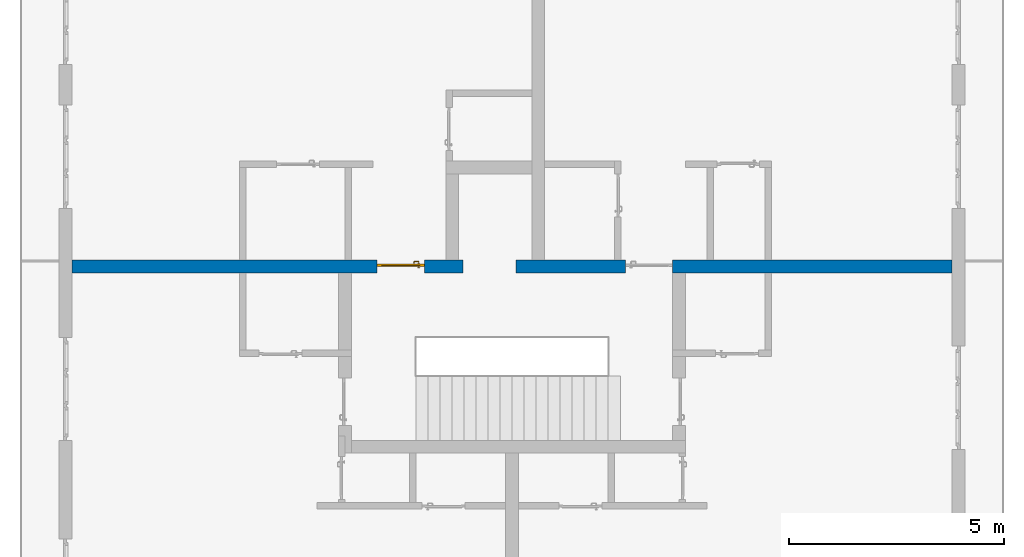
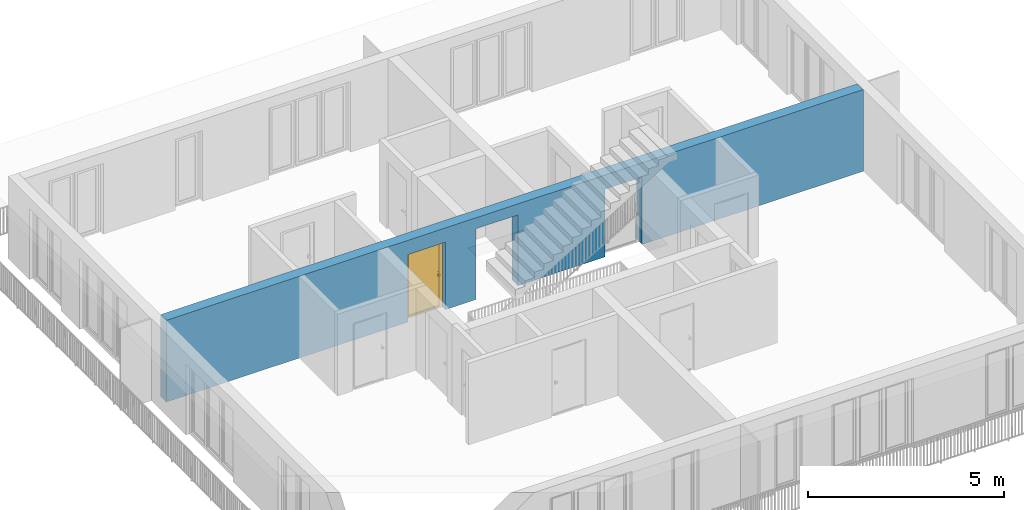
# One storey, part 13 of 48: 1 door, 1 wall, 3 openings.
"""IFC4 building model written with IfcOpenShell, lengths in metres."""

import ifcopenshell
import ifcopenshell.guid

model = None  # the IFC model being written
_history = None  # IfcOwnerHistory: only IFC2X3 demands one
_inside = {}  # id of a spatial element -> (the spatial element, [elements in it])
_under = {}  # id of a project, library or spatial element -> (it, [spatial elements below it])
_declared = {}  # id of a project -> (the project, [libraries it declares])
_typed = {}  # id of a type object -> (the type object, [elements of that type])
_made_of = {}  # id of a material, layer set ... -> (it, [elements and type objects made of it])


def new_model(schema):
    """Start an empty IFC model of exactly this schema.

    Asked for "IFC4X3", IfcOpenShell would pick the latest addendum, in which some entities
    have other attributes; the version numbers below select the first issue.
    IFC2X3 requires an IfcOwnerHistory on every rooted entity: one is made here for all.
    """
    global model, _history
    if schema == "IFC4X3":
        model = ifcopenshell.file(schema_version=(4, 3, 0, 0))
    else:
        model = ifcopenshell.file(schema=schema)
    _inside.clear()
    _under.clear()
    _declared.clear()
    _typed.clear()
    _made_of.clear()
    _history = None
    if model.schema == "IFC2X3":
        org = make("IfcOrganization", Name="unknown")
        user = make(
            "IfcPersonAndOrganization",
            ThePerson=make("IfcPerson", FamilyName="unknown"),
            TheOrganization=org,
        )
        app = make(
            "IfcApplication",
            ApplicationDeveloper=org,
            Version="unknown",
            ApplicationFullName="unknown",
            ApplicationIdentifier="unknown",
        )
        _history = make(
            "IfcOwnerHistory",
            OwningUser=user,
            OwningApplication=app,
            ChangeAction="ADDED",
            CreationDate=0,
        )
    return model


def make(cls, **values):
    """One entity of the class cls with the attributes given. An attribute that is None is left unset."""
    return model.create_entity(
        cls, **{name: value for name, value in values.items() if value is not None}
    )


def entity(cls, *values):
    """Any entity or typed value of the class cls, its attributes in the order of the schema. None: left unset."""
    e = model.create_entity(cls)
    for i, value in enumerate(values):
        if value is not None:
            e[i] = value
    return e


def rooted(cls, **values):
    """An entity with a GlobalId (a new one), such as an element, a storey or a relation."""
    return make(cls, GlobalId=ifcopenshell.guid.new(), OwnerHistory=_history, **values)


def si_unit(unit_type, name, prefix=None):
    """IfcSIUnit, for example si_unit("LENGTHUNIT", "METRE", prefix="MILLI")."""
    return make("IfcSIUnit", UnitType=unit_type, Prefix=prefix, Name=name)


def converted_unit(unit_type, name, factor, base, dimensions=None, offset=None):
    """IfcConversionBasedUnit, such as the inch: factor (a typed value) times the base unit."""
    return make(
        "IfcConversionBasedUnit"
        if offset is None
        else "IfcConversionBasedUnitWithOffset",
        ConversionOffset=offset,
        Dimensions=None
        if dimensions is None
        else entity("IfcDimensionalExponents", *dimensions),
        UnitType=unit_type,
        Name=name,
        ConversionFactor=make(
            "IfcMeasureWithUnit", ValueComponent=factor, UnitComponent=base
        ),
    )


def derived_unit(unit_type, elements):
    """IfcDerivedUnit: a product of units, each with its exponent."""
    return make(
        "IfcDerivedUnit",
        Elements=[
            make("IfcDerivedUnitElement", Unit=unit, Exponent=power)
            for unit, power in elements
        ],
        UnitType=unit_type,
    )


def assignment(units):
    """IfcUnitAssignment: the units of a project."""
    return None if units is None else make("IfcUnitAssignment", Units=units)


def point(xyz):
    """IfcCartesianPoint."""
    return None if xyz is None else make("IfcCartesianPoint", Coordinates=xyz)


def direction(xyz):
    """IfcDirection."""
    return None if xyz is None else make("IfcDirection", DirectionRatios=xyz)


def frame(location, z_axis=None, x_axis=None):
    """IfcAxis2Placement3D, a coordinate frame: its origin and axes. An axis left out is left unset."""
    return make(
        "IfcAxis2Placement3D",
        Location=point(location),
        Axis=direction(z_axis),
        RefDirection=direction(x_axis),
    )


def origin_with_axes():
    """The frame at (0, 0, 0) with the z axis (0, 0, 1) and the x axis (1, 0, 0) written out."""
    return frame((0.0, 0.0, 0.0), z_axis=(0.0, 0.0, 1.0), x_axis=(1.0, 0.0, 0.0))


def place(relative_to, where):
    """IfcLocalPlacement: puts the frame where relative to a parent placement (None: the world)."""
    return make(
        "IfcLocalPlacement", PlacementRelTo=relative_to, RelativePlacement=where
    )


def context(
    kind, dimensions, precision=None, world=None, true_north=None, identifier=None
):
    """IfcGeometricRepresentationContext, for example the 3D "Model" context."""
    return make(
        "IfcGeometricRepresentationContext",
        ContextIdentifier=identifier,
        ContextType=kind,
        CoordinateSpaceDimension=dimensions,
        Precision=precision,
        WorldCoordinateSystem=world,
        TrueNorth=true_north,
    )


def subcontext(parent, identifier, kind, view, scale=None):
    """IfcGeometricRepresentationSubContext, for example "Body" below "Model"."""
    return make(
        "IfcGeometricRepresentationSubContext",
        ContextIdentifier=identifier,
        ContextType=kind,
        ParentContext=parent,
        TargetScale=scale,
        TargetView=view,
    )


def project(units=None, contexts=None):
    """IfcProject with its units and contexts."""
    return rooted(
        "IfcProject",
        Name="project",
        RepresentationContexts=contexts,
        UnitsInContext=assignment(units),
    )


def spatial(cls, under=None, at=None, **own):
    """A site, building, storey or space (cls), placed at a placement, below another one or the project."""
    s = rooted(cls, ObjectPlacement=at, **own)
    if under is not None:
        _under.setdefault(under.id(), (under, []))[1].append(s)
    return s


def point_list(points):
    """IfcCartesianPointList2D or 3D."""
    cls = (
        "IfcCartesianPointList2D" if len(points[0]) == 2 else "IfcCartesianPointList3D"
    )
    return make(cls, CoordList=points)


def polygons(points, faces, closed=None, point_numbers=None):
    """IfcPolygonalFaceSet: a face is its outer loop, then its inner loops; points numbered from 1."""
    made = []
    for loops in faces:
        if len(loops) == 1:
            made.append(make("IfcIndexedPolygonalFace", CoordIndex=loops[0]))
        else:
            made.append(
                make(
                    "IfcIndexedPolygonalFaceWithVoids",
                    CoordIndex=loops[0],
                    InnerCoordIndices=loops[1:],
                )
            )
    return make(
        "IfcPolygonalFaceSet",
        Coordinates=point_list(points),
        Closed=closed,
        Faces=made,
        PnIndex=point_numbers,
    )


def shape(context_of_items, identifier, shape_type, items):
    """IfcShapeRepresentation: the items that make up one representation, for example the "Body"."""
    return make(
        "IfcShapeRepresentation",
        ContextOfItems=context_of_items,
        RepresentationIdentifier=identifier,
        RepresentationType=shape_type,
        Items=items,
    )


def source(mapping_origin, context_of_items, identifier, shape_type, items):
    """IfcRepresentationMap: a shape defined once, which mapped items show again and again."""
    return make(
        "IfcRepresentationMap",
        MappingOrigin=mapping_origin,
        MappedRepresentation=shape(context_of_items, identifier, shape_type, items),
    )


def transform(
    local_origin,
    x_axis=None,
    y_axis=None,
    z_axis=None,
    scale=None,
    scale2=None,
    scale3=None,
    uniform=True,
):
    """IfcCartesianTransformationOperator3D, or its non-uniform kind. x_axis, y_axis, z_axis: its Axis1, 2, 3."""
    if uniform:
        return make(
            "IfcCartesianTransformationOperator3D",
            Axis1=direction(x_axis),
            Axis2=direction(y_axis),
            LocalOrigin=point(local_origin),
            Scale=scale,
            Axis3=direction(z_axis),
        )
    return make(
        "IfcCartesianTransformationOperator3DnonUniform",
        Axis1=direction(x_axis),
        Axis2=direction(y_axis),
        LocalOrigin=point(local_origin),
        Scale=scale,
        Axis3=direction(z_axis),
        Scale2=scale2,
        Scale3=scale3,
    )


def mapped(mapping_source, mapping_target):
    """IfcMappedItem: shows the shape of a source again, moved by a transform."""
    return make(
        "IfcMappedItem", MappingSource=mapping_source, MappingTarget=mapping_target
    )


def material(Name=None, Category=None):
    """IfcMaterial."""
    return make("IfcMaterial", Name=Name, Category=Category)


def made_of(thing, what):
    """Note that an element or type object is made of a material, layer set ...; save() writes the relation."""
    if what is not None:
        _made_of.setdefault(what.id(), (what, []))[1].append(thing)
    return thing


def type_object(cls, material=None, **own):
    """A type object (cls), such as IfcWallType, which elements share."""
    return made_of(rooted(cls, **own), material)


def element(
    cls,
    number,
    at=None,
    inside=None,
    cuts=None,
    type_object=None,
    material=None,
    context=None,
    identifier="Body",
    shape_type=None,
    held_by="IfcProductDefinitionShape",
    body=None,
    shapes=None,
    **own,
):
    """One element of the class cls, such as IfcWall. Its Tag is "e" and its number.

    at: its placement. inside: the storey or other place that contains it. cuts: it is an
    opening in that element (IfcRelVoidsElement). A single representation is given by context,
    identifier, shape_type and body (its items); several are given by shapes. held_by: the class
    of the entity that holds the representations. save() writes the other relations.
    """
    e = rooted(cls, Tag="e%d" % number, ObjectPlacement=at, **own)
    if body is not None:
        shapes = [shape(context, identifier, shape_type, body)]
    if shapes is not None:
        e.Representation = make(held_by, Representations=shapes)
    if inside is not None:
        _inside.setdefault(inside.id(), (inside, []))[1].append(e)
    if cuts is not None:
        rooted(
            "IfcRelVoidsElement", RelatingBuildingElement=cuts, RelatedOpeningElement=e
        )
    if type_object is not None:
        _typed.setdefault(type_object.id(), (type_object, []))[1].append(e)
    return made_of(e, material)


def fill(opening, filler):
    """IfcRelFillsElement: the door or window that sits in an opening."""
    return rooted(
        "IfcRelFillsElement",
        RelatingOpeningElement=opening,
        RelatedBuildingElement=filler,
    )


def aggregate(whole, parts):
    """IfcRelAggregates: a whole, such as a stair, and the parts it consists of."""
    return rooted("IfcRelAggregates", RelatingObject=whole, RelatedObjects=parts)


def save(model, path):
    """Write the relations noted so far, then the file.

    IfcRelAggregates (storeys below a building ...), IfcRelContainedInSpatialStructure (elements
    in a storey), IfcRelDefinesByType, IfcRelAssociatesMaterial and IfcRelDeclares: one each for
    every whole, place, type object, material and project.
    """
    for whole, parts in _under.values():
        aggregate(whole, parts)
    for where, things in _inside.values():
        rooted(
            "IfcRelContainedInSpatialStructure",
            RelatedElements=things,
            RelatingStructure=where,
        )
    for kind, things in _typed.values():
        rooted("IfcRelDefinesByType", RelatedObjects=things, RelatingType=kind)
    for what, things in _made_of.values():
        rooted("IfcRelAssociatesMaterial", RelatedObjects=things, RelatingMaterial=what)
    for by, libraries in _declared.values():
        rooted("IfcRelDeclares", RelatingContext=by, RelatedDefinitions=libraries)
    model.write(path)


model = new_model("IFC4")

# Units and contexts
model_context = context("Model", 3, precision=1e-05, world=origin_with_axes(), true_north=direction((0.0, 1.0)))
body_context = subcontext(model_context, "Body", "Model", "MODEL_VIEW")
ifc_project = project(units=[si_unit("LENGTHUNIT", "METRE"), si_unit("AREAUNIT", "SQUARE_METRE"), si_unit("VOLUMEUNIT", "CUBIC_METRE"), converted_unit("PLANEANGLEUNIT", "DEGREE", entity("IfcPlaneAngleMeasure", 0.0174532925199), si_unit("PLANEANGLEUNIT", "RADIAN"), dimensions=[0, 0, 0, 0, 0, 0, 0]), converted_unit("TIMEUNIT", "Year", entity("IfcTimeMeasure", 31556926.0), si_unit("TIMEUNIT", "SECOND"), dimensions=[0, 0, 1, 0, 0, 0, 0]), si_unit("MASSUNIT", "GRAM", prefix="KILO"), si_unit("THERMODYNAMICTEMPERATUREUNIT", "DEGREE_CELSIUS"), si_unit("LUMINOUSINTENSITYUNIT", "LUMEN"), si_unit("ENERGYUNIT", "JOULE", prefix="MEGA"), derived_unit("THERMALCONDUCTANCEUNIT", [(si_unit("POWERUNIT", "WATT"), 1), (si_unit("LENGTHUNIT", "METRE"), -1), (si_unit("THERMODYNAMICTEMPERATUREUNIT", "KELVIN"), -1)]), derived_unit("SPECIFICHEATCAPACITYUNIT", [(si_unit("ENERGYUNIT", "JOULE"), 1), (si_unit("MASSUNIT", "GRAM", prefix="KILO"), -1), (si_unit("THERMODYNAMICTEMPERATUREUNIT", "KELVIN"), -1)]), derived_unit("MASSDENSITYUNIT", [(si_unit("MASSUNIT", "GRAM", prefix="KILO"), 1), (si_unit("VOLUMEUNIT", "CUBIC_METRE"), -1)])], contexts=[model_context])

# Site, building, storey
site_placement = place(None, origin_with_axes())
site = spatial("IfcSite", under=ifc_project, at=site_placement, CompositionType="ELEMENT")
building_placement = place(site_placement, origin_with_axes())
building = spatial("IfcBuilding", under=site, at=building_placement, CompositionType="ELEMENT")
storey_placement = place(building_placement, frame((0.0, 0.0, 3.4), z_axis=(0.0, 0.0, 1.0), x_axis=(1.0, 0.0, 0.0)))
storey = spatial("IfcBuildingStorey", under=building, at=storey_placement, Name="1. Geschoss", CompositionType="ELEMENT", Elevation=3.4)

# Wall, openings, door
ifc_material = material()
wall_type = type_object("IfcWallType", Name="300", PredefinedType="NOTDEFINED")
wall_placement = place(storey_placement, frame((-11.7421993804, 1.37118776896, 0.0), z_axis=(0.0, 0.0, 1.0), x_axis=(1.0, 0.0, 0.0)))
wall = element("IfcWall", 1, at=wall_placement, inside=storey, type_object=wall_type, material=ifc_material, Name="Wand-001", PredefinedType="NOTDEFINED", context=body_context, shape_type="Tessellation", body=[
    polygons([(9.4, 0.3, 2.2), (9.4, 0.3, 0.0), (8.5, 0.3, 0.0), (8.5, 0.3, 2.1), (7.4, 0.3, 2.1), (7.4, 0.3, 0.0), (0.3, 0.3, 0.0), (0.3, 0.3, 2.54), (20.78, 0.3, 2.54), (20.78, 0.3, 0.0), (14.28, 0.3, 0.0), (14.28, 0.3, 2.1), (13.18, 0.3, 2.1), (13.18, 0.3, 0.0), (10.63, 0.3, 0.0), (10.63, 0.3, 2.2), (9.4, 0.0, 2.2), (9.4, 0.0, 0.0), (8.5, 0.0, 0.0), (8.5, 0.0, 2.1), (7.4, 0.0, 2.1), (7.4, 0.0, 0.0), (0.3, 0.0, 0.0), (0.3, 0.0, 2.54), (20.78, 0.0, 2.54), (20.78, 0.0, 0.0), (14.28, 0.0, 0.0), (14.28, 0.0, 2.1), (13.18, 0.0, 2.1), (13.18, 0.0, 0.0), (10.63, 0.0, 0.0), (10.63, 0.0, 2.2)], [[[1, 2, 3, 4, 5, 6, 7, 8, 9, 10, 11, 12, 13, 14, 15, 16]], [[2, 1, 17, 18]], [[2, 18, 19, 3]], [[20, 4, 3, 19]], [[21, 5, 4, 20]], [[22, 6, 5, 21]], [[7, 6, 22, 23]], [[24, 8, 7, 23]], [[25, 9, 8, 24]], [[9, 25, 26, 10]], [[10, 26, 27, 11]], [[11, 27, 28, 12]], [[12, 28, 29, 13]], [[13, 29, 30, 14]], [[31, 15, 14, 30]], [[16, 15, 31, 32]], [[1, 16, 32, 17]], [[32, 31, 30, 29, 28, 27, 26, 25, 24, 23, 22, 21, 20, 19, 18, 17]]], closed=True),
])
opening_1_placement = place(wall_placement, frame((7.95, 0.0, 0.0), z_axis=(0.0, 0.0, 1.0), x_axis=(1.0, 0.0, 0.0)))
opening_1 = element("IfcOpeningElement", 2, at=opening_1_placement, cuts=wall, context=body_context, identifier="Reference", shape_type="Tessellation", body=[
    polygons([(0.55, 0.15, 0.0), (0.55, 0.15, 2.1), (0.55, -0.001, 2.1), (0.55, -0.001, 0.0), (0.55, 0.301, 0.0), (0.55, 0.301, 2.1), (-0.55, 0.15, 2.1), (-0.55, -0.001, 2.1), (-0.55, 0.301, 2.1), (-0.55, -0.001, 0.0), (-0.55, 0.15, 0.0), (-0.55, 0.301, 0.0)], [[[1, 2, 3, 4]], [[2, 1, 5, 6]], [[7, 8, 3, 2, 6, 9]], [[8, 10, 4, 3]], [[1, 4, 10, 11, 12, 5]], [[6, 5, 12, 9]], [[7, 11, 10, 8]], [[11, 7, 9, 12]]], closed=True),
])
opening_2_placement = place(wall_placement, frame((13.73, 0.0, 0.0), z_axis=(0.0, 0.0, 1.0), x_axis=(1.0, 0.0, 0.0)))
element("IfcOpeningElement", 3, at=opening_2_placement, cuts=wall, context=body_context, identifier="Reference", shape_type="Tessellation", body=[
    polygons([(0.55, 0.15, 0.0), (0.55, 0.15, 2.1), (0.55, -0.001, 2.1), (0.55, -0.001, 0.0), (0.55, 0.301, 0.0), (0.55, 0.301, 2.1), (-0.55, 0.15, 2.1), (-0.55, -0.001, 2.1), (-0.55, 0.301, 2.1), (-0.55, -0.001, 0.0), (-0.55, 0.15, 0.0), (-0.55, 0.301, 0.0)], [[[1, 2, 3, 4]], [[2, 1, 5, 6]], [[7, 8, 3, 2, 6, 9]], [[8, 10, 4, 3]], [[1, 4, 10, 11, 12, 5]], [[6, 5, 12, 9]], [[7, 11, 10, 8]], [[11, 7, 9, 12]]], closed=True),
])
opening_3_placement = place(wall_placement, frame((10.015, 0.0, 0.0), z_axis=(0.0, 0.0, 1.0), x_axis=(1.0, 0.0, 0.0)))
element("IfcOpeningElement", 4, at=opening_3_placement, cuts=wall, context=body_context, identifier="Reference", shape_type="Tessellation", body=[
    polygons([(-0.615, -0.001, 2.2), (-0.615, -0.001, 0.0), (0.615, -0.001, 0.0), (0.615, -0.001, 2.2), (-0.615, 0.301, 2.2), (-0.615, 0.301, 0.0), (0.615, 0.301, 0.0), (0.615, 0.301, 2.2)], [[[1, 2, 3, 4]], [[5, 6, 2, 1]], [[6, 7, 3, 2]], [[7, 8, 4, 3]], [[8, 5, 1, 4]], [[7, 6, 5, 8]]], closed=True),
])
door_type = type_object("IfcDoorType", Name="Eingang 01 1-Fl 26", OperationType="SINGLE_SWING_LEFT", PredefinedType="DOOR")
shared_shape = source(origin_with_axes(), body_context, "Body", "Tessellation", [
    polygons([(-0.55, -0.05, 0.0), (-0.55, -0.05, 2.1), (-0.55, -0.03, 2.1), (-0.55, -0.03, 0.0), (-0.45, -0.05, 0.0), (-0.45, -0.05, 2.0), (-0.1301, -0.05, 2.0), (-0.0001, -0.05, 2.0), (0.45, -0.05, 2.0), (0.45, -0.05, 0.0), (0.55, -0.05, 0.0), (0.55, -0.05, 2.1), (0.55, -0.03, 2.1), (0.55, -0.03, 0.0), (0.45, -0.03, 0.0), (0.45, -0.03, 2.0), (-0.0001, -0.03, 2.0), (-0.1301, -0.03, 2.0), (-0.45, -0.03, 2.0), (-0.45, -0.03, 0.0)], [[[1, 2, 3, 4]], [[1, 5, 6, 7, 8, 9, 10, 11, 12, 2]], [[2, 12, 13, 3]], [[4, 3, 13, 14, 15, 16, 17, 18, 19, 20]], [[5, 1, 4, 20]], [[6, 5, 20, 19]], [[7, 6, 19, 18]], [[8, 7, 18, 17]], [[9, 8, 17, 16]], [[10, 9, 16, 15]], [[11, 10, 15, 14]], [[12, 11, 14, 13]]], closed=True),
    polygons([(-0.55, -0.03, 0.0), (-0.55, -0.03, 2.1), (-0.55, 0.0, 2.1), (-0.55, 0.0, 0.0), (-0.48, -0.03, 0.0), (-0.48, -0.03, 2.03), (-0.1001, -0.03, 2.03), (-0.0301, -0.03, 2.03), (0.48, -0.03, 2.03), (0.48, -0.03, 0.0), (0.55, -0.03, 0.0), (0.55, -0.03, 2.1), (0.55, 0.0, 2.1), (0.55, 0.0, 0.0), (0.48, 0.0, 0.0), (0.48, 0.0, 2.03), (-0.0301, 0.0, 2.03), (-0.1001, 0.0, 2.03), (-0.48, 0.0, 2.03), (-0.48, 0.0, 0.0)], [[[1, 2, 3, 4]], [[1, 5, 6, 7, 8, 9, 10, 11, 12, 2]], [[2, 12, 13, 3]], [[4, 3, 13, 14, 15, 16, 17, 18, 19, 20]], [[5, 1, 4, 20]], [[6, 5, 20, 19]], [[7, 6, 19, 18]], [[8, 7, 18, 17]], [[9, 8, 17, 16]], [[10, 9, 16, 15]], [[11, 10, 15, 14]], [[12, 11, 14, 13]]], closed=True),
    polygons([(-0.48, 0.01, 0.0), (-0.48, 0.01, 2.03), (0.48, 0.01, 2.03), (0.48, 0.01, 0.0), (-0.48, -0.03, 0.0), (-0.48, -0.03, 2.03), (0.48, -0.03, 2.03), (0.48, -0.03, 0.0)], [[[1, 2, 3, 4]], [[1, 5, 6, 2]], [[2, 6, 7, 3]], [[3, 7, 8, 4]], [[4, 8, 5, 1]], [[8, 7, 6, 5]]], closed=True),
    polygons([(-0.445, -0.05, 0.0), (0.445, -0.05, 0.0), (0.445, -0.05, 0.05), (-0.445, -0.05, 0.05), (-0.445, -0.03, 0.0), (0.445, -0.03, 0.0), (0.445, -0.03, 0.07), (0.445, -0.035, 0.07), (-0.445, -0.035, 0.07), (-0.445, -0.03, 0.07)], [[[1, 2, 3, 4]], [[5, 6, 2, 1]], [[2, 6, 7, 8, 3]], [[4, 3, 8, 9]], [[1, 4, 9, 10, 5]], [[10, 7, 6, 5]], [[9, 8, 7, 10]]], closed=True),
    polygons([(0.4335, 0.02, 1.0733826859), (0.42, 0.02, 1.077), (0.42, 0.0199, 1.077), (0.4335, 0.0199, 1.0733826859), (0.443382685902, 0.02, 1.0635), (0.447, 0.02, 1.05), (0.443382685902, 0.02, 1.0365), (0.4335, 0.02, 1.0266173141), (0.42, 0.02, 1.023), (0.4065, 0.02, 1.0266173141), (0.396617314098, 0.02, 1.0365), (0.393, 0.02, 1.05), (0.396617314098, 0.02, 1.0635), (0.4065, 0.02, 1.0733826859), (0.4065, 0.0199, 1.0733826859), (0.42, 0.0101, 1.077), (0.4335, 0.0101, 1.0733826859), (0.443382685902, 0.0199, 1.0635), (0.447, 0.0199, 1.05), (0.443382685902, 0.0199, 1.0365), (0.4335, 0.0199, 1.0266173141), (0.42, 0.0199, 1.023), (0.4065, 0.0199, 1.0266173141), (0.396617314098, 0.0199, 1.0365), (0.393, 0.0199, 1.05), (0.396617314098, 0.0199, 1.0635), (0.4065, 0.0101, 1.0733826859), (0.42, 0.01, 1.077), (0.4335, 0.01, 1.0733826859), (0.443382685902, 0.0101, 1.0635), (0.447, 0.0101, 1.05), (0.443382685902, 0.0101, 1.0365), (0.4335, 0.0101, 1.0266173141), (0.42, 0.0101, 1.023), (0.4065, 0.0101, 1.0266173141), (0.396617314098, 0.0101, 1.0365), (0.393, 0.0101, 1.05), (0.396617314098, 0.0101, 1.0635), (0.4065, 0.01, 1.0733826859), (0.396617314098, 0.01, 1.0635), (0.393, 0.01, 1.05), (0.396617314098, 0.01, 1.0365), (0.4065, 0.01, 1.0266173141), (0.42, 0.01, 1.023), (0.4335, 0.01, 1.0266173141), (0.443382685902, 0.01, 1.0365), (0.447, 0.01, 1.05), (0.443382685902, 0.01, 1.0635)], [[[1, 2, 3, 4]], [[2, 1, 5, 6, 7, 8, 9, 10, 11, 12, 13, 14]], [[2, 14, 15, 3]], [[4, 3, 16, 17]], [[5, 1, 4, 18]], [[6, 5, 18, 19]], [[7, 6, 19, 20]], [[8, 7, 20, 21]], [[9, 8, 21, 22]], [[10, 9, 22, 23]], [[11, 10, 23, 24]], [[12, 11, 24, 25]], [[13, 12, 25, 26]], [[14, 13, 26, 15]], [[3, 15, 27, 16]], [[17, 16, 28, 29]], [[18, 4, 17, 30]], [[19, 18, 30, 31]], [[20, 19, 31, 32]], [[21, 20, 32, 33]], [[22, 21, 33, 34]], [[23, 22, 34, 35]], [[24, 23, 35, 36]], [[25, 24, 36, 37]], [[26, 25, 37, 38]], [[15, 26, 38, 27]], [[16, 27, 39, 28]], [[28, 39, 40, 41, 42, 43, 44, 45, 46, 47, 48, 29]], [[30, 17, 29, 48]], [[31, 30, 48, 47]], [[32, 31, 47, 46]], [[33, 32, 46, 45]], [[34, 33, 45, 44]], [[35, 34, 44, 43]], [[36, 35, 43, 42]], [[37, 36, 42, 41]], [[38, 37, 41, 40]], [[27, 38, 40, 39]]], closed=True),
    polygons([(0.412532169224, 0.019, 0.959692280177), (0.413279754556, 0.019, 0.961639806549), (0.40705, 0.019, 0.972430057958), (0.397569942042, 0.019, 0.96295), (0.415, 0.019, 0.952886751346), (0.415, 0.019, 0.9544), (0.412532169224, 0.02, 0.959692280177), (0.413279754556, 0.02, 0.961639806549), (0.414624817685, 0.02, 0.965143815798), (0.414624817685, 0.019, 0.965143815798), (0.42, 0.019, 0.967425445323), (0.42, 0.019, 0.9759), (0.407, 0.019, 0.972516660498), (0.397483339502, 0.019, 0.963), (0.415, 0.019, 0.95), (0.3941, 0.019, 0.95), (0.415, 0.019, 0.947113248654), (0.415, 0.019, 0.941339745962), (0.415, 0.019, 0.9375), (0.415, 0.02, 0.9375), (0.415, 0.02, 0.941339745962), (0.415, 0.02, 0.947113248654), (0.415, 0.02, 0.95), (0.415, 0.02, 0.952886751346), (0.415, 0.02, 0.9544), (0.396703916638, 0.02, 0.96345), (0.40655, 0.02, 0.973296083362), (0.42, 0.02, 0.9769), (0.42, 0.02, 0.967425445323), (0.425375182315, 0.019, 0.965143815798), (0.426720245444, 0.019, 0.961639806549), (0.43295, 0.019, 0.972430057958), (0.42, 0.019, 0.976), (0.407, 0.0189, 0.972516660498), (0.397483339502, 0.0189, 0.963), (0.394, 0.019, 0.95), (0.397569942042, 0.019, 0.93705), (0.40705, 0.019, 0.927569942042), (0.42, 0.019, 0.9241), (0.42, 0.019, 0.9325), (0.416464466094, 0.019, 0.933964466094), (0.416464466094, 0.02, 0.933964466094), (0.42, 0.02, 0.9231), (0.40655, 0.02, 0.926703916638), (0.42, 0.02, 0.9325), (0.396703916638, 0.02, 0.93655), (0.3931, 0.02, 0.95), (0.396617314098, 0.02, 0.9635), (0.4065, 0.02, 0.973382685902), (0.42, 0.02, 0.977), (0.425375182315, 0.02, 0.965143815798), (0.43345, 0.02, 0.973296083362), (0.426720245444, 0.02, 0.961639806549), (0.427467830776, 0.02, 0.959692280177), (0.427467830776, 0.019, 0.959692280177), (0.425, 0.019, 0.9544), (0.425, 0.019, 0.952886751346), (0.442430057958, 0.019, 0.96295), (0.433, 0.019, 0.972516660498), (0.42, 0.0189, 0.976), (0.407, 0.0101, 0.972516660498), (0.397483339502, 0.0101, 0.963), (0.394, 0.0189, 0.95), (0.397483339502, 0.019, 0.937), (0.407, 0.019, 0.927483339502), (0.42, 0.019, 0.924), (0.43295, 0.019, 0.927569942042), (0.425, 0.019, 0.941339745962), (0.425, 0.019, 0.9375), (0.423535533906, 0.019, 0.933964466094), (0.42, 0.02, 0.923), (0.4065, 0.02, 0.926617314098), (0.43345, 0.02, 0.926703916638), (0.423535533906, 0.02, 0.933964466094), (0.425, 0.02, 0.9375), (0.425, 0.02, 0.941339745962), (0.396617314098, 0.02, 0.9365), (0.393, 0.02, 0.95), (0.396617314098, 0.0199, 0.9635), (0.4065, 0.0199, 0.973382685902), (0.42, 0.0199, 0.977), (0.4335, 0.02, 0.973382685902), (0.443296083362, 0.02, 0.96345), (0.425, 0.02, 0.952886751346), (0.425, 0.02, 0.9544), (0.425, 0.02, 0.95), (0.425, 0.02, 0.947113248654), (0.425, 0.019, 0.947113248654), (0.425, 0.019, 0.95), (0.4459, 0.019, 0.95), (0.442516660498, 0.019, 0.963), (0.433, 0.0189, 0.972516660498), (0.42, 0.0101, 0.976), (0.407, 0.01, 0.972516660498), (0.397483339502, 0.01, 0.963), (0.394, 0.0101, 0.95), (0.397483339502, 0.0189, 0.937), (0.407, 0.0189, 0.927483339502), (0.42, 0.0189, 0.924), (0.433, 0.019, 0.927483339502), (0.442430057958, 0.019, 0.93705), (0.42, 0.0199, 0.923), (0.4065, 0.0199, 0.926617314098), (0.4335, 0.02, 0.926617314098), (0.443296083362, 0.02, 0.93655), (0.396617314098, 0.0199, 0.9365), (0.393, 0.0199, 0.95), (0.396617314098, 0.0101, 0.9635), (0.4065, 0.0101, 0.973382685902), (0.42, 0.0101, 0.977), (0.4335, 0.0199, 0.973382685902), (0.443382685902, 0.02, 0.9635), (0.4469, 0.02, 0.95), (0.446, 0.019, 0.95), (0.442516660498, 0.0189, 0.963), (0.433, 0.0101, 0.972516660498), (0.42, 0.01, 0.976), (0.40695, 0.01, 0.972603263039), (0.397396736961, 0.01, 0.96305), (0.394, 0.01, 0.95), (0.397483339502, 0.0101, 0.937), (0.407, 0.0101, 0.927483339502), (0.42, 0.0101, 0.924), (0.433, 0.0189, 0.927483339502), (0.442516660498, 0.019, 0.937), (0.42, 0.0101, 0.923), (0.4065, 0.0101, 0.926617314098), (0.4335, 0.0199, 0.926617314098), (0.443382685902, 0.02, 0.9365), (0.396617314098, 0.0101, 0.9365), (0.393, 0.0101, 0.95), (0.396617314098, 0.01, 0.9635), (0.4065, 0.01, 0.973382685902), (0.42, 0.01, 0.977), (0.4335, 0.0101, 0.973382685902), (0.443382685902, 0.0199, 0.9635), (0.447, 0.02, 0.95), (0.446, 0.0189, 0.95), (0.442516660498, 0.0101, 0.963), (0.433, 0.01, 0.972516660498), (0.42, 0.01, 0.9761), (0.40655, 0.01, 0.973296083362), (0.396703916638, 0.01, 0.96345), (0.3939, 0.01, 0.95), (0.397483339502, 0.01, 0.937), (0.407, 0.01, 0.927483339502), (0.42, 0.01, 0.924), (0.433, 0.0101, 0.927483339502), (0.442516660498, 0.0189, 0.937), (0.42, 0.01, 0.923), (0.4065, 0.01, 0.926617314098), (0.4335, 0.0101, 0.926617314098), (0.443382685902, 0.0199, 0.9365), (0.396617314098, 0.01, 0.9365), (0.393, 0.01, 0.95), (0.42, 0.01, 0.9769), (0.4335, 0.01, 0.973382685902), (0.443382685902, 0.0101, 0.9635), (0.447, 0.0199, 0.95), (0.446, 0.0101, 0.95), (0.442516660498, 0.01, 0.963), (0.43305, 0.01, 0.972603263039), (0.3931, 0.01, 0.95), (0.397396736961, 0.01, 0.93695), (0.40695, 0.01, 0.927396736961), (0.42, 0.01, 0.9239), (0.433, 0.01, 0.927483339502), (0.442516660498, 0.0101, 0.937), (0.42, 0.01, 0.9231), (0.40655, 0.01, 0.926703916638), (0.4335, 0.01, 0.926617314098), (0.443382685902, 0.0101, 0.9365), (0.396703916638, 0.01, 0.93655), (0.43345, 0.01, 0.973296083362), (0.443382685902, 0.01, 0.9635), (0.447, 0.0101, 0.95), (0.446, 0.01, 0.95), (0.442603263039, 0.01, 0.96305), (0.43305, 0.01, 0.927396736961), (0.442516660498, 0.01, 0.937), (0.43345, 0.01, 0.926703916638), (0.443382685902, 0.01, 0.9365), (0.443296083362, 0.01, 0.96345), (0.447, 0.01, 0.95), (0.4461, 0.01, 0.95), (0.442603263039, 0.01, 0.93695), (0.443296083362, 0.01, 0.93655), (0.4469, 0.01, 0.95)], [[[1, 2, 3, 4, 5, 6]], [[1, 7, 8, 9, 10, 2]], [[10, 11, 12, 3, 2]], [[4, 3, 13, 14]], [[15, 5, 4, 16]], [[6, 5, 15, 17, 18, 19, 20, 21, 22, 23, 24, 25]], [[6, 25, 7, 1]], [[7, 25, 24, 26, 27, 8]], [[9, 8, 27, 28, 29]], [[10, 9, 29, 11]], [[30, 31, 32, 12, 11]], [[3, 12, 33, 13]], [[14, 13, 34, 35]], [[16, 4, 14, 36]], [[17, 15, 16, 37]], [[18, 17, 37, 38]], [[38, 39, 40, 41, 19, 18]], [[19, 41, 42, 20]], [[43, 44, 21, 20, 42, 45]], [[22, 21, 44, 46]], [[23, 22, 46, 47]], [[24, 23, 47, 26]], [[48, 49, 27, 26]], [[49, 50, 28, 27]], [[51, 29, 28, 52, 53]], [[11, 29, 51, 30]], [[30, 51, 53, 54, 55, 31]], [[55, 56, 57, 58, 32, 31]], [[12, 32, 59, 33]], [[13, 33, 60, 34]], [[35, 34, 61, 62]], [[36, 14, 35, 63]], [[37, 16, 36, 64]], [[38, 37, 64, 65]], [[39, 38, 65, 66]], [[39, 67, 68, 69, 70, 40]], [[41, 40, 45, 42]], [[71, 72, 44, 43]], [[73, 43, 45, 74, 75, 76]], [[72, 77, 46, 44]], [[77, 78, 47, 46]], [[78, 48, 26, 47]], [[79, 80, 49, 48]], [[80, 81, 50, 49]], [[50, 82, 52, 28]], [[54, 53, 52, 83, 84, 85]], [[55, 54, 85, 56]], [[85, 84, 86, 87, 76, 75, 69, 68, 88, 89, 57, 56]], [[57, 89, 90, 58]], [[32, 58, 91, 59]], [[33, 59, 92, 60]], [[34, 60, 93, 61]], [[62, 61, 94, 95]], [[63, 35, 62, 96]], [[64, 36, 63, 97]], [[65, 64, 97, 98]], [[66, 65, 98, 99]], [[67, 39, 66, 100]], [[88, 68, 67, 101]], [[70, 69, 75, 74]], [[40, 70, 74, 45]], [[102, 103, 72, 71]], [[104, 71, 43, 73]], [[76, 87, 105, 73]], [[103, 106, 77, 72]], [[106, 107, 78, 77]], [[107, 79, 48, 78]], [[108, 109, 80, 79]], [[109, 110, 81, 80]], [[81, 111, 82, 50]], [[82, 112, 83, 52]], [[86, 84, 83, 113]], [[87, 86, 113, 105]], [[89, 88, 101, 90]], [[58, 90, 114, 91]], [[59, 91, 115, 92]], [[60, 92, 116, 93]], [[61, 93, 117, 94]], [[95, 94, 118, 119]], [[96, 62, 95, 120]], [[97, 63, 96, 121]], [[98, 97, 121, 122]], [[99, 98, 122, 123]], [[100, 66, 99, 124]], [[101, 67, 100, 125]], [[126, 127, 103, 102]], [[128, 102, 71, 104]], [[129, 104, 73, 105]], [[127, 130, 106, 103]], [[130, 131, 107, 106]], [[131, 108, 79, 107]], [[132, 133, 109, 108]], [[133, 134, 110, 109]], [[110, 135, 111, 81]], [[111, 136, 112, 82]], [[112, 137, 113, 83]], [[137, 129, 105, 113]], [[90, 101, 125, 114]], [[91, 114, 138, 115]], [[92, 115, 139, 116]], [[93, 116, 140, 117]], [[94, 117, 141, 118]], [[119, 118, 142, 143]], [[120, 95, 119, 144]], [[121, 96, 120, 145]], [[122, 121, 145, 146]], [[123, 122, 146, 147]], [[124, 99, 123, 148]], [[125, 100, 124, 149]], [[150, 151, 127, 126]], [[152, 126, 102, 128]], [[153, 128, 104, 129]], [[151, 154, 130, 127]], [[154, 155, 131, 130]], [[155, 132, 108, 131]], [[143, 142, 133, 132]], [[142, 156, 134, 133]], [[134, 157, 135, 110]], [[135, 158, 136, 111]], [[136, 159, 137, 112]], [[159, 153, 129, 137]], [[114, 125, 149, 138]], [[115, 138, 160, 139]], [[116, 139, 161, 140]], [[117, 140, 162, 141]], [[118, 141, 156, 142]], [[144, 119, 143, 163]], [[145, 120, 144, 164]], [[146, 145, 164, 165]], [[147, 146, 165, 166]], [[148, 123, 147, 167]], [[149, 124, 148, 168]], [[169, 170, 151, 150]], [[171, 150, 126, 152]], [[172, 152, 128, 153]], [[170, 173, 154, 151]], [[173, 163, 155, 154]], [[163, 143, 132, 155]], [[156, 174, 157, 134]], [[157, 175, 158, 135]], [[158, 176, 159, 136]], [[176, 172, 153, 159]], [[138, 149, 168, 160]], [[139, 160, 177, 161]], [[140, 161, 178, 162]], [[141, 162, 174, 156]], [[164, 144, 163, 173]], [[165, 164, 173, 170]], [[166, 165, 170, 169]], [[167, 147, 166, 179]], [[168, 148, 167, 180]], [[181, 169, 150, 171]], [[182, 171, 152, 172]], [[174, 183, 175, 157]], [[175, 184, 176, 158]], [[184, 182, 172, 176]], [[160, 168, 180, 177]], [[161, 177, 185, 178]], [[162, 178, 183, 174]], [[179, 166, 169, 181]], [[180, 167, 179, 186]], [[187, 181, 171, 182]], [[183, 188, 184, 175]], [[188, 187, 182, 184]], [[177, 180, 186, 185]], [[178, 185, 188, 183]], [[186, 179, 181, 187]], [[185, 186, 187, 188]]], closed=True),
    polygons([(0.43, 0.02, 1.05), (0.427071067812, 0.02, 1.04292893219), (0.427071067812, 0.050696439392, 1.04292893219), (0.43, 0.0509849140336, 1.05), (0.42, 0.02, 1.04), (0.42, 0.05, 1.04), (0.425518993221, 0.0584992452783, 1.04292893219), (0.428277987014, 0.0596420579258, 1.05), (0.427071067812, 0.02, 1.05707106781), (0.427071067812, 0.050696439392, 1.05707106781), (0.412928932188, 0.02, 1.04292893219), (0.412928932188, 0.049303560608, 1.04292893219), (0.418858192988, 0.0557402514855, 1.04), (0.420704557509, 0.0657045575088, 1.04292893219), (0.422816199938, 0.0678161999379, 1.05), (0.425518993221, 0.0584992452783, 1.05707106781), (0.42, 0.02, 1.06), (0.42, 0.05, 1.06), (0.41, 0.02, 1.05), (0.41, 0.0490150859664, 1.05), (0.412197392755, 0.0529812576926, 1.04292893219), (0.415606601718, 0.0606066017178, 1.04), (0.413499245278, 0.0705189932208, 1.04292893219), (0.414642057926, 0.0732779870137, 1.05), (0.420704557509, 0.0657045575088, 1.05707106781), (0.418858192988, 0.0557402514855, 1.06), (0.412928932188, 0.02, 1.05707106781), (0.412928932188, 0.049303560608, 1.05707106781), (0.409438398962, 0.0518384450452, 1.05), (0.410508645927, 0.0555086459268, 1.04292893219), (0.410740251485, 0.0638581929877, 1.04), (0.405696439392, 0.0720710678119, 1.04292893219), (0.405984914034, 0.075, 1.05), (0.413499245278, 0.0705189932208, 1.05707106781), (0.415606601718, 0.0606066017178, 1.06), (0.412197392755, 0.0529812576926, 1.05707106781), (0.408397003498, 0.0533970034977, 1.05), (0.407981257693, 0.0571973927545, 1.04292893219), (0.405, 0.065, 1.04), (0.324303560608, 0.0720710678119, 1.04292893219), (0.324015085966, 0.075, 1.05), (0.405696439392, 0.0720710678119, 1.05707106781), (0.410740251485, 0.0638581929877, 1.06), (0.410508645927, 0.0555086459268, 1.05707106781), (0.406838445045, 0.0544383989617, 1.05), (0.404303560608, 0.0579289321881, 1.04292893219), (0.325, 0.065, 1.04), (0.316500754722, 0.0705189932208, 1.04292893219), (0.315357942074, 0.0732779870137, 1.05), (0.324303560608, 0.0720710678119, 1.05707106781), (0.405, 0.065, 1.06), (0.407981257693, 0.0571973927545, 1.05707106781), (0.404015085966, 0.055, 1.05), (0.325696439392, 0.0579289321881, 1.04292893219), (0.319259748515, 0.0638581929877, 1.04), (0.309295442491, 0.0657045575088, 1.04292893219), (0.307183800062, 0.0678161999379, 1.05), (0.316500754722, 0.0705189932208, 1.05707106781), (0.325, 0.065, 1.06), (0.404303560608, 0.0579289321881, 1.05707106781), (0.325984914034, 0.055, 1.05), (0.322018742307, 0.0571973927545, 1.04292893219), (0.314393398282, 0.0606066017178, 1.04), (0.304481006779, 0.0584992452783, 1.04292893219), (0.301722012986, 0.0596420579258, 1.05), (0.309295442491, 0.0657045575088, 1.05707106781), (0.319259748515, 0.0638581929877, 1.06), (0.325696439392, 0.0579289321881, 1.05707106781), (0.323161554955, 0.0544383989617, 1.05), (0.319491354073, 0.0555086459268, 1.04292893219), (0.311141807012, 0.0557402514855, 1.04), (0.302928932188, 0.050696439392, 1.04292893219), (0.3, 0.0509849140336, 1.05), (0.304481006779, 0.0584992452783, 1.05707106781), (0.314393398282, 0.0606066017178, 1.06), (0.322018742307, 0.0571973927545, 1.05707106781), (0.321602996502, 0.0533970034977, 1.05), (0.317802607245, 0.0529812576926, 1.04292893219), (0.31, 0.05, 1.04), (0.302928932188, 0.02, 1.04292893219), (0.3, 0.02, 1.05), (0.302928932188, 0.050696439392, 1.05707106781), (0.311141807012, 0.0557402514855, 1.06), (0.319491354073, 0.0555086459268, 1.05707106781), (0.320561601038, 0.0518384450452, 1.05), (0.317071067812, 0.049303560608, 1.04292893219), (0.31, 0.02, 1.04), (0.317071067812, 0.02, 1.04292893219), (0.32, 0.02, 1.05), (0.317071067812, 0.02, 1.05707106781), (0.31, 0.02, 1.06), (0.302928932188, 0.02, 1.05707106781), (0.31, 0.05, 1.06), (0.317802607245, 0.0529812576926, 1.05707106781), (0.32, 0.0490150859664, 1.05), (0.317071067812, 0.049303560608, 1.05707106781)], [[[1, 2, 3, 4]], [[2, 5, 6, 3]], [[4, 3, 7, 8]], [[9, 1, 4, 10]], [[5, 11, 12, 6]], [[3, 6, 13, 7]], [[8, 7, 14, 15]], [[10, 4, 8, 16]], [[17, 9, 10, 18]], [[11, 19, 20, 12]], [[6, 12, 21, 13]], [[7, 13, 22, 14]], [[15, 14, 23, 24]], [[16, 8, 15, 25]], [[18, 10, 16, 26]], [[27, 17, 18, 28]], [[19, 27, 28, 20]], [[12, 20, 29, 21]], [[13, 21, 30, 22]], [[14, 22, 31, 23]], [[24, 23, 32, 33]], [[25, 15, 24, 34]], [[26, 16, 25, 35]], [[28, 18, 26, 36]], [[20, 28, 36, 29]], [[21, 29, 37, 30]], [[22, 30, 38, 31]], [[23, 31, 39, 32]], [[33, 32, 40, 41]], [[34, 24, 33, 42]], [[35, 25, 34, 43]], [[36, 26, 35, 44]], [[29, 36, 44, 37]], [[30, 37, 45, 38]], [[31, 38, 46, 39]], [[32, 39, 47, 40]], [[41, 40, 48, 49]], [[42, 33, 41, 50]], [[43, 34, 42, 51]], [[44, 35, 43, 52]], [[37, 44, 52, 45]], [[38, 45, 53, 46]], [[39, 46, 54, 47]], [[40, 47, 55, 48]], [[49, 48, 56, 57]], [[50, 41, 49, 58]], [[51, 42, 50, 59]], [[52, 43, 51, 60]], [[45, 52, 60, 53]], [[46, 53, 61, 54]], [[47, 54, 62, 55]], [[48, 55, 63, 56]], [[57, 56, 64, 65]], [[58, 49, 57, 66]], [[59, 50, 58, 67]], [[60, 51, 59, 68]], [[53, 60, 68, 61]], [[54, 61, 69, 62]], [[55, 62, 70, 63]], [[56, 63, 71, 64]], [[65, 64, 72, 73]], [[66, 57, 65, 74]], [[67, 58, 66, 75]], [[68, 59, 67, 76]], [[61, 68, 76, 69]], [[62, 69, 77, 70]], [[63, 70, 78, 71]], [[64, 71, 79, 72]], [[73, 72, 80, 81]], [[74, 65, 73, 82]], [[75, 66, 74, 83]], [[76, 67, 75, 84]], [[69, 76, 84, 77]], [[70, 77, 85, 78]], [[71, 78, 86, 79]], [[72, 79, 87, 80]], [[81, 80, 87, 88, 89, 90, 91, 92]], [[82, 73, 81, 92]], [[83, 74, 82, 93]], [[84, 75, 83, 94]], [[77, 84, 94, 85]], [[78, 85, 95, 86]], [[79, 86, 88, 87]], [[86, 95, 89, 88]], [[95, 96, 90, 89]], [[96, 93, 91, 90]], [[93, 82, 92, 91]], [[94, 83, 93, 96]], [[85, 94, 96, 95]]], closed=False),
    polygons([(0.414696699141, -0.035, 1.04469669914), (0.4125, -0.035, 1.05), (0.414696699141, -0.035, 1.05530330086), (0.42, -0.035, 1.0575), (0.425303300859, -0.035, 1.05530330086), (0.4275, -0.035, 1.05), (0.425303300859, -0.035, 1.04469669914), (0.42, -0.035, 1.0425), (0.414696699141, -0.075, 1.04469669914), (0.4125, -0.075, 1.05), (0.414696699141, -0.075, 1.05530330086), (0.42, -0.075, 1.0575), (0.425303300859, -0.075, 1.05530330086), (0.4275, -0.075, 1.05), (0.425303300859, -0.075, 1.04469669914), (0.42, -0.075, 1.0425)], [[[1, 2, 3, 4, 5, 6, 7, 8]], [[1, 9, 10, 2]], [[2, 10, 11, 3]], [[3, 11, 12, 4]], [[4, 12, 13, 5]], [[5, 13, 14, 6]], [[6, 14, 15, 7]], [[7, 15, 16, 8]], [[8, 16, 9, 1]], [[9, 16, 15, 14, 13, 12, 11, 10]]], closed=True),
    polygons([(0.445, -0.03, 0.975), (0.445, -0.035, 0.975), (0.443096988313, -0.035, 0.965432914191), (0.443096988313, -0.03, 0.965432914191), (0.445, -0.03, 1.1), (0.445, -0.035, 1.1), (0.443096988313, -0.035, 1.10956708581), (0.43767766953, -0.035, 1.11767766953), (0.429567085809, -0.035, 1.12309698831), (0.42, -0.035, 1.125), (0.410432914191, -0.035, 1.12309698831), (0.40232233047, -0.035, 1.11767766953), (0.396903011687, -0.035, 1.10956708581), (0.395, -0.035, 1.1), (0.395, -0.035, 0.975), (0.396903011687, -0.035, 0.965432914191), (0.40232233047, -0.035, 0.95732233047), (0.410432914191, -0.035, 0.951903011687), (0.42, -0.035, 0.95), (0.429567085809, -0.035, 0.951903011687), (0.43767766953, -0.035, 0.95732233047), (0.43767766953, -0.03, 0.95732233047), (0.429567085809, -0.03, 0.951903011687), (0.42, -0.03, 0.95), (0.410432914191, -0.03, 0.951903011687), (0.40232233047, -0.03, 0.95732233047), (0.396903011687, -0.03, 0.965432914191), (0.395, -0.03, 0.975), (0.395, -0.03, 1.1), (0.396903011687, -0.03, 1.10956708581), (0.40232233047, -0.03, 1.11767766953), (0.410432914191, -0.03, 1.12309698831), (0.42, -0.03, 1.125), (0.429567085809, -0.03, 1.12309698831), (0.43767766953, -0.03, 1.11767766953), (0.443096988313, -0.03, 1.10956708581)], [[[1, 2, 3, 4]], [[5, 6, 2, 1]], [[2, 6, 7, 8, 9, 10, 11, 12, 13, 14, 15, 16, 17, 18, 19, 20, 21, 3]], [[4, 3, 21, 22]], [[1, 4, 22, 23, 24, 25, 26, 27, 28, 29, 30, 31, 32, 33, 34, 35, 36, 5]], [[36, 7, 6, 5]], [[35, 8, 7, 36]], [[34, 9, 8, 35]], [[33, 10, 9, 34]], [[32, 11, 10, 33]], [[31, 12, 11, 32]], [[30, 13, 12, 31]], [[29, 14, 13, 30]], [[28, 15, 14, 29]], [[27, 16, 15, 28]], [[26, 17, 16, 27]], [[25, 18, 17, 26]], [[24, 19, 18, 25]], [[23, 20, 19, 24]], [[22, 21, 20, 23]]], closed=True),
    polygons([(0.44, -0.075, 1.08), (0.44, -0.09, 1.08), (0.445, -0.09, 1.07866025404), (0.445, -0.075, 1.07866025404), (0.4, -0.075, 1.08), (0.4, -0.09, 1.08), (0.395, -0.09, 1.07866025404), (0.391339745962, -0.09, 1.075), (0.39, -0.09, 1.07), (0.39, -0.09, 1.03), (0.391339745962, -0.09, 1.025), (0.395, -0.09, 1.02133974596), (0.4, -0.09, 1.02), (0.44, -0.09, 1.02), (0.445, -0.09, 1.02133974596), (0.448660254038, -0.09, 1.025), (0.45, -0.09, 1.03), (0.45, -0.09, 1.07), (0.448660254038, -0.09, 1.075), (0.448660254038, -0.075, 1.075), (0.45, -0.075, 1.07), (0.45, -0.075, 1.03), (0.448660254038, -0.075, 1.025), (0.445, -0.075, 1.02133974596), (0.44, -0.075, 1.02), (0.4, -0.075, 1.02), (0.395, -0.075, 1.02133974596), (0.391339745962, -0.075, 1.025), (0.39, -0.075, 1.03), (0.39, -0.075, 1.07), (0.391339745962, -0.075, 1.075), (0.395, -0.075, 1.07866025404)], [[[1, 2, 3, 4]], [[5, 6, 2, 1]], [[2, 6, 7, 8, 9, 10, 11, 12, 13, 14, 15, 16, 17, 18, 19, 3]], [[4, 3, 19, 20]], [[1, 4, 20, 21, 22, 23, 24, 25, 26, 27, 28, 29, 30, 31, 32, 5]], [[32, 7, 6, 5]], [[31, 8, 7, 32]], [[30, 9, 8, 31]], [[29, 10, 9, 30]], [[28, 11, 10, 29]], [[27, 12, 11, 28]], [[26, 13, 12, 27]], [[25, 14, 13, 26]], [[24, 15, 14, 25]], [[23, 16, 15, 24]], [[22, 17, 16, 23]], [[21, 18, 17, 22]], [[20, 19, 18, 21]]], closed=True),
])
door_placement = place(opening_1_placement, frame((-0.45, 0.0, 0.0), z_axis=(0.0, 0.0, 1.0), x_axis=(1.0, 0.0, 0.0)))
door = element("IfcDoor", 5, at=door_placement, inside=storey, type_object=door_type, OverallHeight=2.1, OverallWidth=1.1, PredefinedType="DOOR", context=body_context, shape_type="MappedRepresentation", body=[
    mapped(shared_shape, transform((0.45, 0.2, 0.0))),
])
fill(opening_1, door)

save(model, "model.ifc")
